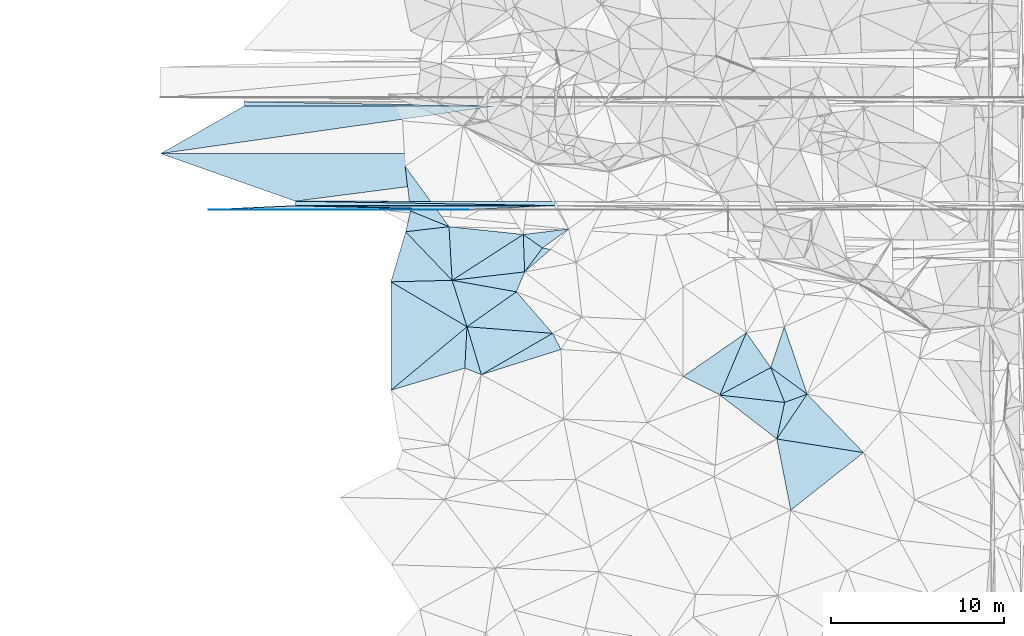
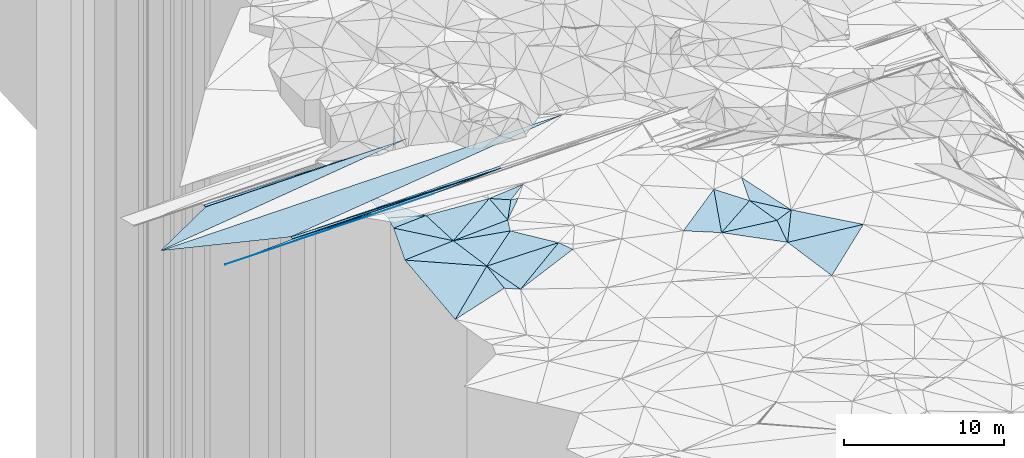
# One storey, part 44 of 275: 49 plates.
"""IFC2X3 building model written with IfcOpenShell, lengths in millimetres."""

from ifc_helpers import new_model, si_unit, frame, origin_with_axes, place, context, subcontext, project, spatial, polyline, outline, extrude, material, type_object, element, save


model = new_model("IFC2X3")

# Units and contexts
model_context = context("Model", 3, precision=1e-05, world=origin_with_axes())
body_context = subcontext(model_context, "Body", "Model", "MODEL_VIEW")
ifc_project = project(units=[si_unit("LENGTHUNIT", "METRE", prefix="MILLI"), si_unit("AREAUNIT", "SQUARE_METRE"), si_unit("VOLUMEUNIT", "CUBIC_METRE"), si_unit("MASSUNIT", "GRAM", prefix="KILO"), si_unit("TIMEUNIT", "SECOND"), si_unit("PLANEANGLEUNIT", "RADIAN"), si_unit("SOLIDANGLEUNIT", "STERADIAN"), si_unit("THERMODYNAMICTEMPERATUREUNIT", "DEGREE_CELSIUS"), si_unit("LUMINOUSINTENSITYUNIT", "LUMEN")], contexts=[model_context])

# Site, building, storey
site_placement = place(None, origin_with_axes())
site = spatial("IfcSite", under=ifc_project, at=site_placement, CompositionType="ELEMENT")
building_placement = place(site_placement, origin_with_axes())
building = spatial("IfcBuilding", under=site, at=building_placement, Name="Undefined", CompositionType="ELEMENT")
storey_placement = place(building_placement, origin_with_axes())
storey = spatial("IfcBuildingStorey", under=building, at=storey_placement, Name="Undefined", CompositionType="ELEMENT", Elevation=0.0)

# Plates
ifc_material = material()
plate_type_1 = type_object("IfcPlateType", PredefinedType="NOTDEFINED")
plate_1_placement = place(storey_placement, frame((-153615.567535843, 63295.7070231726, 48767.4411626867), z_axis=(0.008324340579686, 0.024990848492353, -0.999653021225638), x_axis=(0.999965340787191, -5.73519775278889e-05, 0.0083254990906575)))
element("IfcPlate", 1, at=plate_1_placement, inside=storey, type_object=plate_type_1, material=ifc_material, Name="00_PR", context=body_context, shape_type="SweptSolid", body=[
    extrude(outline(polyline([(0.0, 0.0), (29006.0703125, -2.99005478154868e-07), (7784.8349609375, 2750.85961914063), (0.0, 0.0)])), frame((-8.85201319254618e-08, 2.18876761149539e-07, -0.5000001331573), z_axis=(0.0, 0.0, 1.0), x_axis=(1.0, 0.0, 0.0)), (0.0, 0.0, 1.0), 1.0),
])
plate_type_2 = type_object("IfcPlateType", PredefinedType="NOTDEFINED")
plate_2_placement = place(storey_placement, frame((-130830.601711207, 60294.4009799999, 48882.1441650048), z_axis=(0.008324340579686, 0.024990848492353, -0.999653021225638), x_axis=(-0.999828921479719, 0.0167211159843702, -0.00790772109644352)))
element("IfcPlate", 2, at=plate_2_placement, inside=storey, type_object=plate_type_2, material=ifc_material, Name="00_PR", context=body_context, shape_type="SweptSolid", body=[
    extrude(outline(polyline([(0.0, 0.0), (15002.552734375, 6.20057107880712e-08), (4.11653470993042, 250.044235229492), (0.0, 0.0)])), frame((-8.85201319254618e-08, 2.18876761149539e-07, -0.5000001331573), z_axis=(0.0, 0.0, 1.0), x_axis=(1.0, 0.0, 0.0)), (0.0, 0.0, 1.0), 1.0),
])
plate_3_placement = place(storey_placement, frame((-148781.232418061, 66045.4040448498, 48738.9391635638), z_axis=(0.00832149793297365, -0.0249918019511436, -0.9996530210565), x_axis=(5.72779774420735e-05, 0.999687644773175, -0.0249921909222736)))
element("IfcPlate", 3, at=plate_3_placement, inside=storey, type_object=plate_type_2, material=ifc_material, Name="00_PR", context=body_context, shape_type="SweptSolid", body=[
    extrude(outline(polyline([(0.0, 0.0), (250.078109741211, 1.02591002359986e-09), (-3.01760864257813, 14503.03515625), (0.0, 0.0)])), frame((-8.85201319254618e-08, 2.18876761149539e-07, -0.5000001331573), z_axis=(0.0, 0.0, 1.0), x_axis=(1.0, 0.0, 0.0)), (0.0, 0.0, 1.0), 1.0),
])
plate_4_placement = place(storey_placement, frame((-130830.601711207, 60294.4009799999, 48882.1441650048), z_axis=(0.008324340579686, 0.024990848492353, -0.999653021225638), x_axis=(-0.999965344853481, 5.72919765649429e-05, -0.00832501109232228)))
element("IfcPlate", 4, at=plate_4_placement, inside=storey, type_object=plate_type_2, material=ifc_material, Name="00_PR", context=body_context, shape_type="SweptSolid", body=[
    extrude(outline(polyline([(0.0, 0.0), (15000.51953125, -1.61511707119644e-07), (15000.4677734375, 250.078109741211), (0.0, 0.0)])), frame((-8.85201319254618e-08, 2.18876761149539e-07, -0.5000001331573), z_axis=(0.0, 0.0, 1.0), x_axis=(1.0, 0.0, 0.0)), (0.0, 0.0, 1.0), 1.0),
])
plate_5_placement = place(storey_placement, frame((-130830.601711207, 60294.4009799999, 48882.1441650048), z_axis=(0.008324340579686, 0.024990848492353, -0.999653021225638), x_axis=(-0.999828921479719, 0.0167211159843702, -0.00790772109644352)))
element("IfcPlate", 5, at=plate_5_placement, inside=storey, type_object=plate_type_2, material=ifc_material, Name="00_PR", context=body_context, shape_type="SweptSolid", body=[
    extrude(outline(polyline([(0.0, 0.0), (15002.552734375, 6.20057107880712e-08), (4.11653470993042, 250.044235229492), (0.0, 0.0)])), frame((-8.85201319254618e-08, 2.18876761149539e-07, -0.5000001331573), z_axis=(0.0, 0.0, 1.0), x_axis=(1.0, 0.0, 0.0)), (0.0, 0.0, 1.0), 1.0),
])
plate_6_placement = place(storey_placement, frame((-148781.232418061, 66045.4040448498, 48738.9391635638), z_axis=(0.00832149793297365, -0.0249918019511436, -0.9996530210565), x_axis=(5.72779774420735e-05, 0.999687644773175, -0.0249921909222736)))
element("IfcPlate", 6, at=plate_6_placement, inside=storey, type_object=plate_type_2, material=ifc_material, Name="00_PR", context=body_context, shape_type="SweptSolid", body=[
    extrude(outline(polyline([(0.0, 0.0), (250.078109741211, 1.02591002359986e-09), (-3.01760864257813, 14503.03515625), (0.0, 0.0)])), frame((-8.85201319254618e-08, 2.18876761149539e-07, -0.5000001331573), z_axis=(0.0, 0.0, 1.0), x_axis=(1.0, 0.0, 0.0)), (0.0, 0.0, 1.0), 1.0),
])
plate_7_placement = place(storey_placement, frame((-130830.601711207, 60294.4009799999, 48882.1441650048), z_axis=(0.008324340579686, 0.024990848492353, -0.999653021225638), x_axis=(-0.999965344853481, 5.72919765649429e-05, -0.00832501109232228)))
element("IfcPlate", 7, at=plate_7_placement, inside=storey, type_object=plate_type_2, material=ifc_material, Name="00_PR", context=body_context, shape_type="SweptSolid", body=[
    extrude(outline(polyline([(0.0, 0.0), (15000.51953125, -1.61511707119644e-07), (15000.4677734375, 250.078109741211), (0.0, 0.0)])), frame((-8.85201319254618e-08, 2.18876761149539e-07, -0.5000001331573), z_axis=(0.0, 0.0, 1.0), x_axis=(1.0, 0.0, 0.0)), (0.0, 0.0, 1.0), 1.0),
])
plate_8_placement = place(storey_placement, frame((-130830.601711207, 60294.4009799999, 48882.1441650048), z_axis=(0.008324340579686, 0.024990848492353, -0.999653021225638), x_axis=(-0.999828921479719, 0.0167211159843702, -0.00790772109644352)))
element("IfcPlate", 8, at=plate_8_placement, inside=storey, type_object=plate_type_2, material=ifc_material, Name="00_PR", context=body_context, shape_type="SweptSolid", body=[
    extrude(outline(polyline([(0.0, 0.0), (15002.552734375, 6.20057107880712e-08), (4.11653470993042, 250.044235229492), (0.0, 0.0)])), frame((-8.85201319254618e-08, 2.18876761149539e-07, -0.5000001331573), z_axis=(0.0, 0.0, 1.0), x_axis=(1.0, 0.0, 0.0)), (0.0, 0.0, 1.0), 1.0),
])
plate_9_placement = place(storey_placement, frame((-148781.232418061, 66045.4040448498, 48738.9391635638), z_axis=(0.00832149793297365, -0.0249918019511436, -0.9996530210565), x_axis=(5.72779774420735e-05, 0.999687644773175, -0.0249921909222736)))
element("IfcPlate", 9, at=plate_9_placement, inside=storey, type_object=plate_type_2, material=ifc_material, Name="00_PR", context=body_context, shape_type="SweptSolid", body=[
    extrude(outline(polyline([(0.0, 0.0), (250.078109741211, 1.02591002359986e-09), (-3.01760864257813, 14503.03515625), (0.0, 0.0)])), frame((-8.85201319254618e-08, 2.18876761149539e-07, -0.5000001331573), z_axis=(0.0, 0.0, 1.0), x_axis=(1.0, 0.0, 0.0)), (0.0, 0.0, 1.0), 1.0),
])
plate_10_placement = place(storey_placement, frame((-130830.601711207, 60294.4009799999, 48882.1441650048), z_axis=(0.008324340579686, 0.024990848492353, -0.999653021225638), x_axis=(-0.999965344853481, 5.72919765649429e-05, -0.00832501109232228)))
element("IfcPlate", 10, at=plate_10_placement, inside=storey, type_object=plate_type_2, material=ifc_material, Name="00_PR", context=body_context, shape_type="SweptSolid", body=[
    extrude(outline(polyline([(0.0, 0.0), (15000.51953125, -1.61511707119644e-07), (15000.4677734375, 250.078109741211), (0.0, 0.0)])), frame((-8.85201319254618e-08, 2.18876761149539e-07, -0.5000001331573), z_axis=(0.0, 0.0, 1.0), x_axis=(1.0, 0.0, 0.0)), (0.0, 0.0, 1.0), 1.0),
])
plate_type_3 = type_object("IfcPlateType", PredefinedType="NOTDEFINED")
for number, where, z_axis, x_axis, name in (
    (11, (-150830.615096735, 60065.5596596139, 48704.1296300961), (0.00831791384860372, 0.0499512317397681, -0.998717020360065), (0.999965340787191, -5.73519775278889e-05, 0.0083254990906575), "00_PR"),
    (12, (-150830.615096735, 60065.5596596139, 48704.1296300961), (0.00831791384860372, 0.0499512317397681, -0.998717020360065), (0.999965340787191, -5.73519775278889e-05, 0.0083254990906575), "00_PR"),
    (13, (-150830.615096735, 60065.5596596139, 48704.1296300961), (0.00831791384860372, 0.0499512317397681, -0.998717020360065), (0.999965340787191, -5.73519775278889e-05, 0.0083254990906575), "00_PR"),
):
    element("IfcPlate", number, at=place(storey_placement, frame(where, z_axis=z_axis, x_axis=x_axis)), inside=storey, type_object=plate_type_3, material=ifc_material, Name=name, context=body_context, shape_type="SweptSolid", body=[
        extrude(outline(polyline([(0.0, 0.0), (15000.51953125, -1.61511707119644e-07), (10000.3388671875, 20.0253238677979), (0.0, 0.0)])), frame((-8.85201319254618e-08, 2.18876761149539e-07, -0.5000001331573), z_axis=(0.0, 0.0, 1.0), x_axis=(1.0, 0.0, 0.0)), (0.0, 0.0, 1.0), 1.0),
    ])
plate_type_4 = type_object("IfcPlateType", PredefinedType="NOTDEFINED")
plate_11_placement = place(storey_placement, frame((-145830.601822875, 60295.2728599158, 48757.2586310674), z_axis=(0.00831791896881435, 0.0499369262044137, -0.998717735711789), x_axis=(0.999965340787191, -5.73519775278889e-05, 0.0083254990906575)))
element("IfcPlate", 14, at=plate_11_placement, inside=storey, type_object=plate_type_4, material=ifc_material, Name="00_PR", context=body_context, shape_type="SweptSolid", body=[
    extrude(outline(polyline([(0.0, 0.0), (15000.51953125, -1.61511707119644e-07), (10000.2509765625, 230.286987304688), (0.0, 0.0)])), frame((-8.85201319254618e-08, 2.18876761149539e-07, -0.5000001331573), z_axis=(0.0, 0.0, 1.0), x_axis=(1.0, 0.0, 0.0)), (0.0, 0.0, 1.0), 1.0),
])
plate_12_placement = place(storey_placement, frame((-150830.615096735, 60065.5596596139, 48704.1296300961), z_axis=(0.00831791896881435, 0.0499369262044137, -0.998717735711789), x_axis=(0.998890039694259, 0.0458915250081009, 0.0106139781436128)))
element("IfcPlate", 15, at=plate_12_placement, inside=storey, type_object=plate_type_4, material=ifc_material, Name="00_PR", context=body_context, shape_type="SweptSolid", body=[
    extrude(outline(polyline([(0.0, 0.0), (5005.5693359375, 1.71130523085594e-08), (14984.63671875, 690.116271972656), (0.0, 0.0)])), frame((-8.85201319254618e-08, 2.18876761149539e-07, -0.5000001331573), z_axis=(0.0, 0.0, 1.0), x_axis=(1.0, 0.0, 0.0)), (0.0, 0.0, 1.0), 1.0),
])
plate_13_placement = place(storey_placement, frame((-145830.601822875, 60295.2728599158, 48757.2586310674), z_axis=(0.00831791896881435, 0.0499369262044137, -0.998717735711789), x_axis=(0.999965340787191, -5.73519775278889e-05, 0.0083254990906575)))
element("IfcPlate", 16, at=plate_13_placement, inside=storey, type_object=plate_type_4, material=ifc_material, Name="00_PR", context=body_context, shape_type="SweptSolid", body=[
    extrude(outline(polyline([(0.0, 0.0), (15000.51953125, -1.61511707119644e-07), (10000.2509765625, 230.286987304688), (0.0, 0.0)])), frame((-8.85201319254618e-08, 2.18876761149539e-07, -0.5000001331573), z_axis=(0.0, 0.0, 1.0), x_axis=(1.0, 0.0, 0.0)), (0.0, 0.0, 1.0), 1.0),
])
plate_14_placement = place(storey_placement, frame((-150830.615096735, 60065.5596596139, 48704.1296300961), z_axis=(0.00831791896881435, 0.0499369262044137, -0.998717735711789), x_axis=(0.998890039694259, 0.0458915250081009, 0.0106139781436128)))
element("IfcPlate", 17, at=plate_14_placement, inside=storey, type_object=plate_type_4, material=ifc_material, Name="00_PR", context=body_context, shape_type="SweptSolid", body=[
    extrude(outline(polyline([(0.0, 0.0), (5005.5693359375, 1.71130523085594e-08), (14984.63671875, 690.116271972656), (0.0, 0.0)])), frame((-8.85201319254618e-08, 2.18876761149539e-07, -0.5000001331573), z_axis=(0.0, 0.0, 1.0), x_axis=(1.0, 0.0, 0.0)), (0.0, 0.0, 1.0), 1.0),
])
plate_15_placement = place(storey_placement, frame((-145830.601822875, 60295.2728599158, 48757.2586310674), z_axis=(0.00831791896881435, 0.0499369262044137, -0.998717735711789), x_axis=(0.999965340787191, -5.73519775278889e-05, 0.0083254990906575)))
element("IfcPlate", 18, at=plate_15_placement, inside=storey, type_object=plate_type_4, material=ifc_material, Name="00_PR", context=body_context, shape_type="SweptSolid", body=[
    extrude(outline(polyline([(0.0, 0.0), (15000.51953125, -1.61511707119644e-07), (10000.2509765625, 230.286987304688), (0.0, 0.0)])), frame((-8.85201319254618e-08, 2.18876761149539e-07, -0.5000001331573), z_axis=(0.0, 0.0, 1.0), x_axis=(1.0, 0.0, 0.0)), (0.0, 0.0, 1.0), 1.0),
])
plate_16_placement = place(storey_placement, frame((-150830.615096735, 60065.5596596139, 48704.1296300961), z_axis=(0.00831791896881435, 0.0499369262044137, -0.998717735711789), x_axis=(0.998890039694259, 0.0458915250081009, 0.0106139781436128)))
element("IfcPlate", 19, at=plate_16_placement, inside=storey, type_object=plate_type_4, material=ifc_material, Name="00_PR", context=body_context, shape_type="SweptSolid", body=[
    extrude(outline(polyline([(0.0, 0.0), (5005.5693359375, 1.71130523085594e-08), (14984.63671875, 690.116271972656), (0.0, 0.0)])), frame((-8.85201319254618e-08, 2.18876761149539e-07, -0.5000001331573), z_axis=(0.0, 0.0, 1.0), x_axis=(1.0, 0.0, 0.0)), (0.0, 0.0, 1.0), 1.0),
])
plate_type_5 = type_object("IfcPlateType", PredefinedType="NOTDEFINED")
plate_17_placement = place(storey_placement, frame((-140297.806400099, 49629.5467958364, 47159.5035157262), z_axis=(-0.0265578310251023, 0.115743586111215, -0.992924017176218), x_axis=(-0.00191663172069537, 0.993266644937242, 0.115834790015614)))
element("IfcPlate", 20, at=plate_17_placement, inside=storey, type_object=plate_type_5, material=ifc_material, Name="00", context=body_context, shape_type="SweptSolid", body=[
    extrude(outline(polyline([(0.0, 0.0), (6302.0791015625, -2.91038304567337e-11), (3667.7578125, 4390.9169921875), (0.0, 0.0)])), frame((-8.85201319254618e-08, 2.18876761149539e-07, -0.5000001331573), z_axis=(0.0, 0.0, 1.0), x_axis=(1.0, 0.0, 0.0)), (0.0, 0.0, 1.0), 1.0),
])
plate_type_6 = type_object("IfcPlateType", PredefinedType="NOTDEFINED")
plate_18_placement = place(storey_placement, frame((-119778.1556997, 52950.067618076, 47869.5055314386), z_axis=(0.0801993776025634, 0.125267669954911, -0.988876165501136), x_axis=(0.574276832472214, -0.816682791471825, -0.0568800298828116)))
element("IfcPlate", 21, at=plate_18_placement, inside=storey, type_object=plate_type_6, material=ifc_material, Name="00", context=body_context, shape_type="SweptSolid", body=[
    extrude(outline(polyline([(0.0, 0.0), (2461.32080078125, 3.9508449845016e-09), (2101.31079101563, 3350.49145507813), (0.0, 0.0)])), frame((-8.85201319254618e-08, 2.18876761149539e-07, -0.5000001331573), z_axis=(0.0, 0.0, 1.0), x_axis=(1.0, 0.0, 0.0)), (0.0, 0.0, 1.0), 1.0),
])
plate_type_7 = type_object("IfcPlateType", PredefinedType="NOTDEFINED")
for number, where, z_axis, x_axis, name in (
    (22, (-148781.232418061, 66045.4040448498, 48738.9391635638), (0.00832149793297365, -0.0249918019511436, -0.9996530210565), (0.999965340787191, -5.73519775278889e-05, 0.0083254990906575), "00_PR"),
    (23, (-148781.232418061, 66045.4040448498, 48738.9391635638), (0.00832149793297365, -0.0249918019511436, -0.9996530210565), (0.999965340787191, -5.73519775278889e-05, 0.0083254990906575), "00_PR"),
    (24, (-148781.232418061, 66045.4040448498, 48738.9391635638), (0.00832149793297365, -0.0249918019511436, -0.9996530210565), (0.999965340787191, -5.73519775278889e-05, 0.0083254990906575), "00_PR"),
):
    element("IfcPlate", number, at=place(storey_placement, frame(where, z_axis=z_axis, x_axis=x_axis)), inside=storey, type_object=plate_type_7, material=ifc_material, Name=name, context=body_context, shape_type="SweptSolid", body=[
        extrude(outline(polyline([(0.0, 0.0), (14503.03515625, 1.02263584267348e-07), (-4833.77294921875, 2750.85815429688), (0.0, 0.0)])), frame((-8.85201319254618e-08, 2.18876761149539e-07, -0.5000001331573), z_axis=(0.0, 0.0, 1.0), x_axis=(1.0, 0.0, 0.0)), (0.0, 0.0, 1.0), 1.0),
    ])
plate_type_8 = type_object("IfcPlateType", PredefinedType="NOTDEFINED")
plate_19_placement = place(storey_placement, frame((-135084.336014294, 50523.9714862687, 47089.5084429189), z_axis=(-0.161776764249225, 0.0862980997778932, -0.983046751952203), x_axis=(-0.914558824610597, 0.361086833506088, 0.182204431876478)))
element("IfcPlate", 25, at=plate_19_placement, inside=storey, type_object=plate_type_8, material=ifc_material, Name="00", context=body_context, shape_type="SweptSolid", body=[
    extrude(outline(polyline([(0.0, 0.0), (1042.78479003906, 3.52156348526478e-09), (1829.81201171875, 2272.15502929688), (0.0, 0.0)])), frame((-8.85201319254618e-08, 2.18876761149539e-07, -0.5000001331573), z_axis=(0.0, 0.0, 1.0), x_axis=(1.0, 0.0, 0.0)), (0.0, 0.0, 1.0), 1.0),
])
plate_type_9 = type_object("IfcPlateType", PredefinedType="NOTDEFINED")
plate_20_placement = place(storey_placement, frame((-132581.927833358, 56462.9663271632, 47889.5110237831), z_axis=(0.0369085938954281, 0.205760830534092, -0.977906046772686), x_axis=(0.585748859306237, 0.788388987030901, 0.187992231089033)))
element("IfcPlate", 26, at=plate_20_placement, inside=storey, type_object=plate_type_9, material=ifc_material, Name="00", context=body_context, shape_type="SweptSolid", body=[
    extrude(outline(polyline([(0.0, 0.0), (1755.39172363281, -4.51109372079372e-09), (1966.45568847656, 433.995361328125), (0.0, 0.0)])), frame((-8.85201319254618e-08, 2.18876761149539e-07, -0.5000001331573), z_axis=(0.0, 0.0, 1.0), x_axis=(1.0, 0.0, 0.0)), (0.0, 0.0, 1.0), 1.0),
])
plate_type_10 = type_object("IfcPlateType", PredefinedType="NOTDEFINED")
plate_21_placement = place(storey_placement, frame((-118014.405666704, 46808.816085094, 46939.5028474661), z_axis=(0.00685505261523486, 0.106698824711857, -0.994267755214234), x_axis=(0.208763859365545, 0.972229241316625, 0.105773122066535)))
element("IfcPlate", 27, at=plate_21_placement, inside=storey, type_object=plate_type_10, material=ifc_material, Name="00", context=body_context, shape_type="SweptSolid", body=[
    extrude(outline(polyline([(0.0, 0.0), (2174.46533203125, 4.55474946647882e-09), (2914.37133789063, 1169.88854980469), (0.0, 0.0)])), frame((-8.85201319254618e-08, 2.18876761149539e-07, -0.5000001331573), z_axis=(0.0, 0.0, 1.0), x_axis=(1.0, 0.0, 0.0)), (0.0, 0.0, 1.0), 1.0),
])
plate_type_11 = type_object("IfcPlateType", PredefinedType="NOTDEFINED")
plate_22_placement = place(storey_placement, frame((-139175.843554061, 59976.7128989521, 48219.5005678285), z_axis=(-0.0359332390628956, -0.0333398216025768, -0.998797906798947), x_axis=(0.92701488386751, -0.374444398230123, -0.0208518038113885)))
element("IfcPlate", 28, at=plate_22_placement, inside=storey, type_object=plate_type_11, material=ifc_material, Name="00", context=body_context, shape_type="SweptSolid", body=[
    extrude(outline(polyline([(0.0, 0.0), (2397.8740234375, -1.83931661013048e-08), (186.540237426758, 1214.78503417969), (0.0, 0.0)])), frame((-8.85201319254618e-08, 2.18876761149539e-07, -0.5000001331573), z_axis=(0.0, 0.0, 1.0), x_axis=(1.0, 0.0, 0.0)), (0.0, 0.0, 1.0), 1.0),
])
plate_type_12 = type_object("IfcPlateType", PredefinedType="NOTDEFINED")
plate_23_placement = place(storey_placement, frame((-130968.387232423, 52912.1456461742, 47749.5070689634), z_axis=(0.069449561772004, 0.152754380035898, -0.985820905514549), x_axis=(0.461770887519238, -0.880885492448357, -0.103963438927876)))
element("IfcPlate", 29, at=plate_23_placement, inside=storey, type_object=plate_type_12, material=ifc_material, Name="00", context=body_context, shape_type="SweptSolid", body=[
    extrude(outline(polyline([(0.0, 0.0), (1058.06433105469, 5.67524693906307e-09), (271.722625732422, 4796.35986328125), (0.0, 0.0)])), frame((-8.85201319254618e-08, 2.18876761149539e-07, -0.5000001331573), z_axis=(0.0, 0.0, 1.0), x_axis=(1.0, 0.0, 0.0)), (0.0, 0.0, 1.0), 1.0),
])
plate_type_13 = type_object("IfcPlateType", PredefinedType="NOTDEFINED")
plate_24_placement = place(storey_placement, frame((-132581.898106522, 56462.9447430129, 47889.5089894975), z_axis=(0.0963180710557194, 0.16259304357042, -0.981980820266166), x_axis=(-0.0369817526723924, 0.986471151585345, 0.159709163979908)))
element("IfcPlate", 30, at=plate_24_placement, inside=storey, type_object=plate_type_13, material=ifc_material, Name="00", context=body_context, shape_type="SweptSolid", body=[
    extrude(outline(polyline([(0.0, 0.0), (2191.4833984375, -3.14321368932724e-09), (1379.88720703125, 1085.03979492188), (0.0, 0.0)])), frame((-8.85201319254618e-08, 2.18876761149539e-07, -0.5000001331573), z_axis=(0.0, 0.0, 1.0), x_axis=(1.0, 0.0, 0.0)), (0.0, 0.0, 1.0), 1.0),
])
plate_type_14 = type_object("IfcPlateType", PredefinedType="NOTDEFINED")
plate_25_placement = place(storey_placement, frame((-139456.399865651, 58781.2151297877, 48269.5006582152), z_axis=(-0.0434184836344052, 0.0296748445694847, -0.998616161935439), x_axis=(0.992225085624692, 0.117976524609956, -0.0396348217862635)))
element("IfcPlate", 31, at=plate_25_placement, inside=storey, type_object=plate_type_14, material=ifc_material, Name="00", context=body_context, shape_type="SweptSolid", body=[
    extrude(outline(polyline([(0.0, 0.0), (2523.03393554688, -2.03581294044852e-08), (2339.32641601563, 3103.619140625), (0.0, 0.0)])), frame((-8.85201319254618e-08, 2.18876761149539e-07, -0.5000001331573), z_axis=(0.0, 0.0, 1.0), x_axis=(1.0, 0.0, 0.0)), (0.0, 0.0, 1.0), 1.0),
])
plate_type_15 = type_object("IfcPlateType", PredefinedType="NOTDEFINED")
plate_26_placement = place(storey_placement, frame((-131553.733753072, 57846.7989413615, 48219.5000225915), z_axis=(-0.0124003286692361, 0.00802488039414749, -0.999890910621531), x_axis=(-0.818650284154768, 0.574102645297073, 0.014760247837418)))
element("IfcPlate", 32, at=plate_26_placement, inside=storey, type_object=plate_type_15, material=ifc_material, Name="00", context=body_context, shape_type="SweptSolid", body=[
    extrude(outline(polyline([(0.0, 0.0), (1354.99072265625, 5.05679054185748e-09), (-611.664672851563, 1768.32299804688), (0.0, 0.0)])), frame((-8.85201319254618e-08, 2.18876761149539e-07, -0.5000001331573), z_axis=(0.0, 0.0, 1.0), x_axis=(1.0, 0.0, 0.0)), (0.0, 0.0, 1.0), 1.0),
])
plate_type_16 = type_object("IfcPlateType", PredefinedType="NOTDEFINED")
plate_27_placement = place(storey_placement, frame((-118364.803980489, 50939.9261908967, 47729.509310018), z_axis=(-0.175377522954966, 0.0790698660762752, -0.981320885705007), x_axis=(0.31520691138379, 0.948809715279004, 0.020117833085782)))
element("IfcPlate", 33, at=plate_27_placement, inside=storey, type_object=plate_type_16, material=ifc_material, Name="00", context=body_context, shape_type="SweptSolid", body=[
    extrude(outline(polyline([(0.0, 0.0), (2485.35717773438, -9.16770659387112e-10), (-809.702575683594, 2528.23681640625), (0.0, 0.0)])), frame((-8.85201319254618e-08, 2.18876761149539e-07, -0.5000001331573), z_axis=(0.0, 0.0, 1.0), x_axis=(1.0, 0.0, 0.0)), (0.0, 0.0, 1.0), 1.0),
])
plate_type_17 = type_object("IfcPlateType", PredefinedType="NOTDEFINED")
plate_28_placement = place(storey_placement, frame((-116261.933878633, 49398.6460695881, 47229.5163927349), z_axis=(-0.0468330189307586, 0.249840861502954, -0.967153665278322), x_axis=(-0.938100118975166, -0.34364131071144, -0.0433453152174899)))
element("IfcPlate", 34, at=plate_28_placement, inside=storey, type_object=plate_type_17, material=ifc_material, Name="00", context=body_context, shape_type="SweptSolid", body=[
    extrude(outline(polyline([(0.0, 0.0), (1384.23266601563, -2.3283064365387e-09), (1421.29284667969, 2242.21459960938), (0.0, 0.0)])), frame((-8.85201319254618e-08, 2.18876761149539e-07, -0.5000001331573), z_axis=(0.0, 0.0, 1.0), x_axis=(1.0, 0.0, 0.0)), (0.0, 0.0, 1.0), 1.0),
])
plate_type_18 = type_object("IfcPlateType", PredefinedType="NOTDEFINED")
plate_29_placement = place(storey_placement, frame((-136773.242789748, 55976.7267948395, 48069.5120113474), z_axis=(-0.000394130330955228, 0.21818139335101, -0.975908153596789), x_axis=(0.983620339069233, -0.175825083323737, -0.0397060277984029)))
element("IfcPlate", 35, at=plate_29_placement, inside=storey, type_object=plate_type_18, material=ifc_material, Name="00", context=body_context, shape_type="SweptSolid", body=[
    extrude(outline(polyline([(0.0, 0.0), (3777.76391601563, 7.87258613854647e-09), (1339.15197753906, 2548.85693359375), (0.0, 0.0)])), frame((-8.85201319254618e-08, 2.18876761149539e-07, -0.5000001331573), z_axis=(0.0, 0.0, 1.0), x_axis=(1.0, 0.0, 0.0)), (0.0, 0.0, 1.0), 1.0),
])
plate_type_19 = type_object("IfcPlateType", PredefinedType="NOTDEFINED")
plate_30_placement = place(storey_placement, frame((-135915.460396632, 53294.4540218604, 47469.5015288954), z_axis=(0.00454537710882858, 0.078886013577911, -0.996873280015431), x_axis=(-0.0509358933215949, -0.995571257293089, -0.0790152290599091)))
element("IfcPlate", 36, at=plate_30_placement, inside=storey, type_object=plate_type_19, material=ifc_material, Name="00", context=body_context, shape_type="SweptSolid", body=[
    extrude(outline(polyline([(0.0, 0.0), (2404.59985351563, -7.01402314007282e-09), (3896.4072265625, 4189.3447265625), (0.0, 0.0)])), frame((-8.85201319254618e-08, 2.18876761149539e-07, -0.5000001331573), z_axis=(0.0, 0.0, 1.0), x_axis=(1.0, 0.0, 0.0)), (0.0, 0.0, 1.0), 1.0),
])
plate_type_20 = type_object("IfcPlateType", PredefinedType="NOTDEFINED")
plate_31_placement = place(storey_placement, frame((-130968.38803197, 52912.1470265838, 47749.5072150218), z_axis=(0.0677982826427346, 0.155512831112658, -0.985504516595445), x_axis=(-0.856742305798529, -0.497109885669343, -0.137384071219458)))
element("IfcPlate", 37, at=plate_31_placement, inside=storey, type_object=plate_type_20, material=ifc_material, Name="00", context=body_context, shape_type="SweptSolid", body=[
    extrude(outline(polyline([(0.0, 0.0), (4804.05029296875, 7.9890014603734e-09), (4086.73901367188, 2827.78442382813), (0.0, 0.0)])), frame((-8.85201319254618e-08, 2.18876761149539e-07, -0.5000001331573), z_axis=(0.0, 0.0, 1.0), x_axis=(1.0, 0.0, 0.0)), (0.0, 0.0, 1.0), 1.0),
])
plate_type_21 = type_object("IfcPlateType", PredefinedType="NOTDEFINED")
plate_32_placement = place(storey_placement, frame((-136773.218783109, 55976.6758555316, 48069.5039300092), z_axis=(0.0476155602305166, 0.116300166230456, -0.992072088992883), x_axis=(-0.998402690264546, -0.024697006679972, -0.05081462322567)))
element("IfcPlate", 38, at=plate_32_placement, inside=storey, type_object=plate_type_21, material=ifc_material, Name="00", context=body_context, shape_type="SweptSolid", body=[
    extrude(outline(polyline([(0.0, 0.0), (3542.28735351563, -1.85536919161677e-08), (2599.42211914063, 2889.27416992188), (0.0, 0.0)])), frame((-8.85201319254618e-08, 2.18876761149539e-07, -0.5000001331573), z_axis=(0.0, 0.0, 1.0), x_axis=(1.0, 0.0, 0.0)), (0.0, 0.0, 1.0), 1.0),
])
plate_type_22 = type_object("IfcPlateType", PredefinedType="NOTDEFINED")
plate_33_placement = place(storey_placement, frame((-140309.849985232, 55889.2495086474, 47889.5140272637), z_axis=(0.0437406577901392, 0.23139397812006, -0.971876320189899), x_axis=(0.998402690264533, 0.0246970066766944, 0.0508146232275149)))
element("IfcPlate", 39, at=plate_33_placement, inside=storey, type_object=plate_type_22, material=ifc_material, Name="00", context=body_context, shape_type="SweptSolid", body=[
    extrude(outline(polyline([(0.0, 0.0), (3542.28735351563, -1.85536919161677e-08), (4301.9658203125, 2777.20874023438), (0.0, 0.0)])), frame((-8.85201319254618e-08, 2.18876761149539e-07, -0.5000001331573), z_axis=(0.0, 0.0, 1.0), x_axis=(1.0, 0.0, 0.0)), (0.0, 0.0, 1.0), 1.0),
])
plate_type_23 = type_object("IfcPlateType", PredefinedType="NOTDEFINED")
plate_34_placement = place(storey_placement, frame((-136773.26353443, 55976.6133352379, 48069.5004245562), z_axis=(-0.0418927264092646, -0.00874098751748649, -0.999083877665543), x_axis=(0.992435000090038, 0.11513556968339, -0.0426212527967813)))
element("IfcPlate", 40, at=plate_34_placement, inside=storey, type_object=plate_type_23, material=ifc_material, Name="00", context=body_context, shape_type="SweptSolid", body=[
    extrude(outline(polyline([(0.0, 0.0), (4223.2451171875, -1.92521838471293e-08), (3617.69189453125, 1088.02807617188), (0.0, 0.0)])), frame((-8.85201319254618e-08, 2.18876761149539e-07, -0.5000001331573), z_axis=(0.0, 0.0, 1.0), x_axis=(1.0, 0.0, 0.0)), (0.0, 0.0, 1.0), 1.0),
])
plate_type_24 = type_object("IfcPlateType", PredefinedType="NOTDEFINED")
plate_35_placement = place(storey_placement, frame((-139487.5157771, 62561.4891468073, 48659.5081071246), z_axis=(0.0478457877280662, 0.173232803565373, -0.983718037023598), x_axis=(0.584676815757502, -0.803353291912124, -0.113033222946268)))
element("IfcPlate", 41, at=plate_35_placement, inside=storey, type_object=plate_type_24, material=ifc_material, Name="00", context=body_context, shape_type="SweptSolid", body=[
    extrude(outline(polyline([(0.0, 0.0), (4335.0087890625, 2.05036485567689e-08), (2308.39208984375, 1281.64953613281), (0.0, 0.0)])), frame((-8.85201319254618e-08, 2.18876761149539e-07, -0.5000001331573), z_axis=(0.0, 0.0, 1.0), x_axis=(1.0, 0.0, 0.0)), (0.0, 0.0, 1.0), 1.0),
])
plate_type_25 = type_object("IfcPlateType", PredefinedType="NOTDEFINED")
plate_36_placement = place(storey_placement, frame((-121301.185687045, 49346.6121712757, 47289.5181667187), z_axis=(-0.000643179566195876, 0.267276958752872, -0.963619537805176), x_axis=(0.871413356727218, 0.472852624546577, 0.13057242119535)))
element("IfcPlate", 42, at=plate_36_placement, inside=storey, type_object=plate_type_25, material=ifc_material, Name="00", context=body_context, shape_type="SweptSolid", body=[
    extrude(outline(polyline([(0.0, 0.0), (3369.77734375, 1.36788003146648e-09), (3043.73217773438, 2218.69213867188), (0.0, 0.0)])), frame((-8.85201319254618e-08, 2.18876761149539e-07, -0.5000001331573), z_axis=(0.0, 0.0, 1.0), x_axis=(1.0, 0.0, 0.0)), (0.0, 0.0, 1.0), 1.0),
])
plate_type_26 = type_object("IfcPlateType", PredefinedType="NOTDEFINED")
plate_37_placement = place(storey_placement, frame((-135915.429736507, 53294.4782704163, 47469.5051436428), z_axis=(0.0658614669306714, 0.127409004917269, -0.989661160518958), x_axis=(0.810227493607515, 0.572064552478445, 0.12756785018225)))
element("IfcPlate", 43, at=plate_37_placement, inside=storey, type_object=plate_type_26, material=ifc_material, Name="00", context=body_context, shape_type="SweptSolid", body=[
    extrude(outline(polyline([(0.0, 0.0), (3527.53466796875, -1.83354131877422e-09), (3825.22119140625, 3172.61450195313), (0.0, 0.0)])), frame((-8.85201319254618e-08, 2.18876761149539e-07, -0.5000001331573), z_axis=(0.0, 0.0, 1.0), x_axis=(1.0, 0.0, 0.0)), (0.0, 0.0, 1.0), 1.0),
])
plate_type_27 = type_object("IfcPlateType", PredefinedType="NOTDEFINED")
plate_38_placement = place(storey_placement, frame((-117560.468847608, 48922.8977177538, 47169.5032266039), z_axis=(-0.0191639307882225, 0.112202337141788, -0.993500568342397), x_axis=(-0.208763859424598, -0.972229241296336, -0.105773122136479)))
element("IfcPlate", 44, at=plate_38_placement, inside=storey, type_object=plate_type_27, material=ifc_material, Name="00", context=body_context, shape_type="SweptSolid", body=[
    extrude(outline(polyline([(0.0, 0.0), (2174.46533203125, 4.55474946647882e-09), (356.363433837891, 3749.65405273438), (0.0, 0.0)])), frame((-8.85201319254618e-08, 2.18876761149539e-07, -0.5000001331573), z_axis=(0.0, 0.0, 1.0), x_axis=(1.0, 0.0, 0.0)), (0.0, 0.0, 1.0), 1.0),
])
plate_type_28 = type_object("IfcPlateType", PredefinedType="NOTDEFINED")
plate_39_placement = place(storey_placement, frame((-116261.8945009, 49398.5660680548, 47229.5022599616), z_axis=(0.0319691911098481, 0.0898356457844657, -0.995443382401164), x_axis=(0.693374210477645, -0.719314513492868, -0.0426478009165789)))
element("IfcPlate", 45, at=plate_39_placement, inside=storey, type_object=plate_type_28, material=ifc_material, Name="00", context=body_context, shape_type="SweptSolid", body=[
    extrude(outline(polyline([(0.0, 0.0), (4689.57373046875, 2.72993929684162e-08), (660.081359863281, 3070.25927734375), (0.0, 0.0)])), frame((-8.85201319254618e-08, 2.18876761149539e-07, -0.5000001331573), z_axis=(0.0, 0.0, 1.0), x_axis=(1.0, 0.0, 0.0)), (0.0, 0.0, 1.0), 1.0),
])
plate_type_29 = type_object("IfcPlateType", PredefinedType="NOTDEFINED")
plate_40_placement = place(storey_placement, frame((-132663.021463318, 58624.7773709643, 48239.5071347977), z_axis=(-0.0605817423229314, 0.157311403012505, -0.985689086365146), x_axis=(0.0369817526796701, -0.986471151589683, -0.159709163951428)))
element("IfcPlate", 46, at=plate_40_placement, inside=storey, type_object=plate_type_29, material=ifc_material, Name="00", context=body_context, shape_type="SweptSolid", body=[
    extrude(outline(polyline([(0.0, 0.0), (2191.4833984375, -3.14321368932724e-09), (2487.40185546875, 4212.865234375), (0.0, 0.0)])), frame((-8.85201319254618e-08, 2.18876761149539e-07, -0.5000001331573), z_axis=(0.0, 0.0, 1.0), x_axis=(1.0, 0.0, 0.0)), (0.0, 0.0, 1.0), 1.0),
])
plate_type_30 = type_object("IfcPlateType", PredefinedType="NOTDEFINED")
plate_41_placement = place(storey_placement, frame((-119778.206801824, 52950.0889360326, 47869.5072016667), z_axis=(-0.0219441933771153, 0.16790360592931, -0.985559146623359), x_axis=(-0.385088461331132, -0.911152958191981, -0.146653209060096)))
element("IfcPlate", 47, at=plate_41_placement, inside=storey, type_object=plate_type_30, material=ifc_material, Name="00", context=body_context, shape_type="SweptSolid", body=[
    extrude(outline(polyline([(0.0, 0.0), (3954.90844726563, -5.23868948221207e-10), (3762.4638671875, 2383.603515625), (0.0, 0.0)])), frame((-8.85201319254618e-08, 2.18876761149539e-07, -0.5000001331573), z_axis=(0.0, 0.0, 1.0), x_axis=(1.0, 0.0, 0.0)), (0.0, 0.0, 1.0), 1.0),
])
plate_type_31 = type_object("IfcPlateType", PredefinedType="NOTDEFINED")
plate_42_placement = place(storey_placement, frame((-136773.232717356, 55976.6343841617, 48069.5003525834), z_axis=(0.0198364768108117, 0.0333596307156323, -0.999246540762714), x_axis=(-0.0578047905628675, 0.997809637912884, 0.0321641520351788)))
element("IfcPlate", 48, at=plate_42_placement, inside=storey, type_object=plate_type_31, material=ifc_material, Name="00", context=body_context, shape_type="SweptSolid", body=[
    extrude(outline(polyline([(0.0, 0.0), (3109.05126953125, 6.40284270048141e-10), (2410.15649414063, 4257.5283203125), (0.0, 0.0)])), frame((-8.85201319254618e-08, 2.18876761149539e-07, -0.5000001331573), z_axis=(0.0, 0.0, 1.0), x_axis=(1.0, 0.0, 0.0)), (0.0, 0.0, 1.0), 1.0),
])
plate_type_32 = type_object("IfcPlateType", PredefinedType="NOTDEFINED")
plate_43_placement = place(storey_placement, frame((-117211.212966324, 42692.0216391236, 46619.5019636164), z_axis=(0.0309824843290849, 0.0834665734351715, -0.996028823269583), x_axis=(-0.190933900558859, 0.978650821762377, 0.0760711159455644)))
element("IfcPlate", 49, at=plate_43_placement, inside=storey, type_object=plate_type_32, material=ifc_material, Name="00", context=body_context, shape_type="SweptSolid", body=[
    extrude(outline(polyline([(0.0, 0.0), (4206.58984375, 8.73114913702011e-09), (2491.1865234375, 4766.62255859375), (0.0, 0.0)])), frame((-8.85201319254618e-08, 2.18876761149539e-07, -0.5000001331573), z_axis=(0.0, 0.0, 1.0), x_axis=(1.0, 0.0, 0.0)), (0.0, 0.0, 1.0), 1.0),
])

save(model, "model.ifc")
